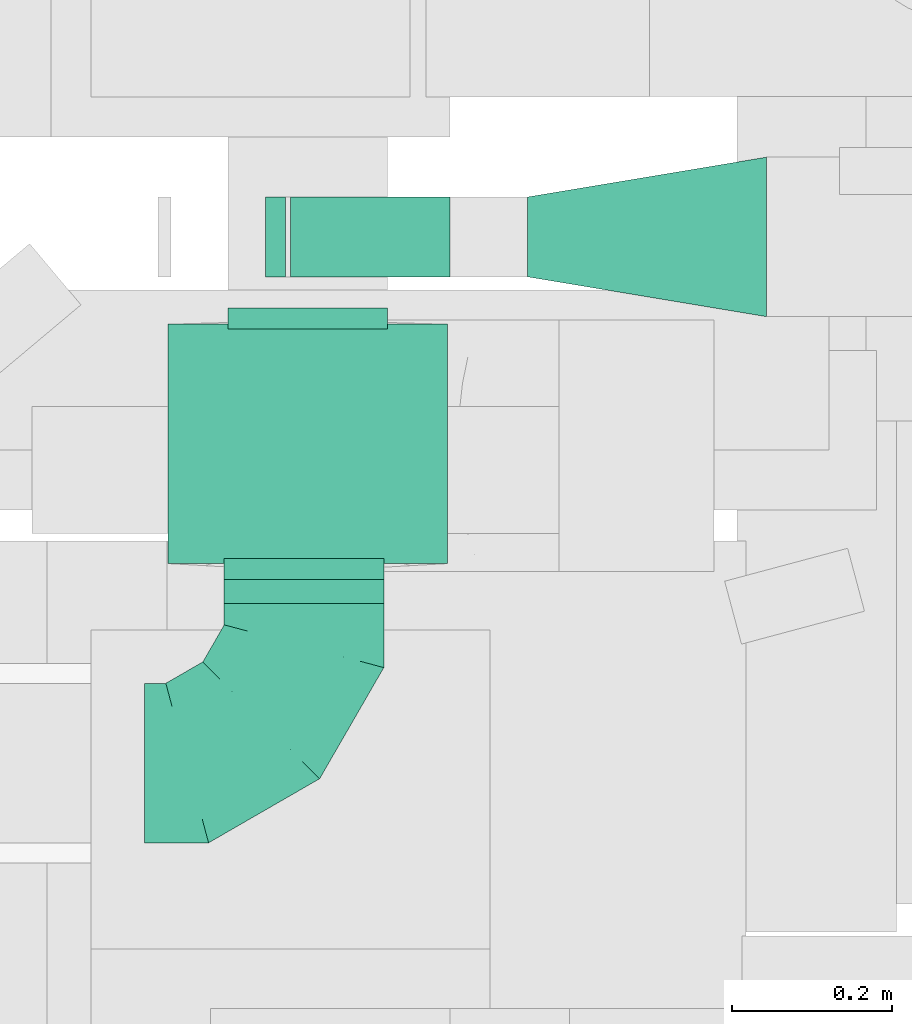
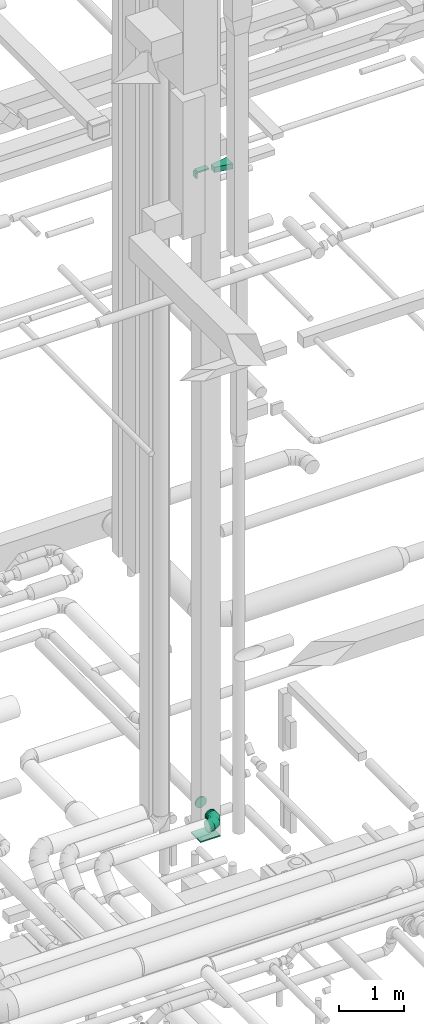
# One storey, part 197 of 337: 7 flow fittings, 1 flow segment.
"""IFC2X3 building model written with IfcOpenShell, lengths in millimetres."""

from ifc_helpers import new_model, entity, si_unit, converted_unit, derived_unit, direction, frame, origin, origin_2d_with_axis, place, context, subcontext, project, spatial, polyline, rectangle, circle, outline, extrude, faceted_brep, source, transform, mapped, material, type_object, type_shapes, element, save


model = new_model("IFC2X3")

# Units and contexts
model_context = context("Model", 3, precision=0.01, world=origin(), true_north=direction((6.12303176911189e-17, 1.0)))
body_context = subcontext(model_context, "Body", "Model", "MODEL_VIEW")
ifc_project = project(units=[si_unit("LENGTHUNIT", "METRE", prefix="MILLI"), si_unit("AREAUNIT", "SQUARE_METRE"), si_unit("VOLUMEUNIT", "CUBIC_METRE"), converted_unit("PLANEANGLEUNIT", "DEGREE", entity("IfcRatioMeasure", 0.0174532925199433), si_unit("PLANEANGLEUNIT", "RADIAN"), dimensions=[0, 0, 0, 0, 0, 0, 0]), si_unit("MASSUNIT", "GRAM", prefix="KILO"), derived_unit("MASSDENSITYUNIT", [(si_unit("MASSUNIT", "GRAM", prefix="KILO"), 1), (si_unit("LENGTHUNIT", "METRE"), -3)]), derived_unit("MOMENTOFINERTIAUNIT", [(si_unit("LENGTHUNIT", "METRE"), 4)]), si_unit("TIMEUNIT", "SECOND"), si_unit("FREQUENCYUNIT", "HERTZ"), si_unit("THERMODYNAMICTEMPERATUREUNIT", "DEGREE_CELSIUS"), derived_unit("THERMALTRANSMITTANCEUNIT", [(si_unit("MASSUNIT", "GRAM", prefix="KILO"), 1), (si_unit("THERMODYNAMICTEMPERATUREUNIT", "KELVIN"), -1), (si_unit("TIMEUNIT", "SECOND"), -3)]), derived_unit("VOLUMETRICFLOWRATEUNIT", [(si_unit("LENGTHUNIT", "METRE"), 3), (si_unit("TIMEUNIT", "SECOND"), -1)]), derived_unit("MASSFLOWRATEUNIT", [(si_unit("MASSUNIT", "GRAM", prefix="KILO"), 1), (si_unit("TIMEUNIT", "SECOND"), -1)]), derived_unit("ROTATIONALFREQUENCYUNIT", [(si_unit("TIMEUNIT", "SECOND"), -1)]), si_unit("ELECTRICCURRENTUNIT", "AMPERE"), si_unit("ELECTRICVOLTAGEUNIT", "VOLT"), si_unit("POWERUNIT", "WATT"), si_unit("FORCEUNIT", "NEWTON", prefix="KILO"), si_unit("ILLUMINANCEUNIT", "LUX"), si_unit("LUMINOUSFLUXUNIT", "LUMEN"), si_unit("LUMINOUSINTENSITYUNIT", "CANDELA"), derived_unit("USERDEFINED", [(si_unit("MASSUNIT", "GRAM", prefix="KILO"), -1), (si_unit("LENGTHUNIT", "METRE"), -2), (si_unit("TIMEUNIT", "SECOND"), 3), (si_unit("LUMINOUSFLUXUNIT", "LUMEN"), 1)]), derived_unit("LINEARVELOCITYUNIT", [(si_unit("LENGTHUNIT", "METRE"), 1), (si_unit("TIMEUNIT", "SECOND"), -1)]), si_unit("PRESSUREUNIT", "PASCAL"), derived_unit("USERDEFINED", [(si_unit("LENGTHUNIT", "METRE"), -2), (si_unit("MASSUNIT", "GRAM", prefix="KILO"), 1), (si_unit("TIMEUNIT", "SECOND"), -2)]), derived_unit("LINEARFORCEUNIT", [(si_unit("MASSUNIT", "GRAM", prefix="KILO"), 1), (si_unit("LENGTHUNIT", "METRE"), 1), (si_unit("TIMEUNIT", "SECOND"), -2), (si_unit("LENGTHUNIT", "METRE"), -1)]), derived_unit("PLANARFORCEUNIT", [(si_unit("MASSUNIT", "GRAM", prefix="KILO"), 1), (si_unit("LENGTHUNIT", "METRE"), 1), (si_unit("TIMEUNIT", "SECOND"), -2), (si_unit("LENGTHUNIT", "METRE"), -2)])], contexts=[model_context])

# Site, building, storey
site_placement = place(None, origin())
site = spatial("IfcSite", under=ifc_project, at=site_placement, CompositionType="ELEMENT")
building_placement = place(site_placement, origin())
building = spatial("IfcBuilding", under=site, at=building_placement, CompositionType="ELEMENT")
storey_placement = place(building_placement, origin())
storey = spatial("IfcBuildingStorey", under=building, at=storey_placement, CompositionType="ELEMENT", Elevation=0.0)

# Flow segment
duct_segment_type = type_object("IfcDuctSegmentType", PredefinedType="NOTDEFINED")
flow_segment_placement = place(storey_placement, frame((52465.56, 12006.96, 3348.4)))
element("IfcFlowSegment", 1, at=flow_segment_placement, inside=storey, type_object=duct_segment_type, context=body_context, shape_type="SweptSolid", body=[
    extrude(circle(Radius=100.0, at=origin_2d_with_axis()), frame((101.6, 0.0, 101.6), z_axis=(0.0, 1.0, 0.0), x_axis=(1.0, 0.0, 0.0)), (0.0, 0.0, 1.0), 29.9999999999542),
])

# Flow fittings
ifc_material = material()
duct_fitting_type_1 = type_object("IfcDuctFittingType", PredefinedType="NOTDEFINED", material=ifc_material)
shared_shape_1 = source(origin(), body_context, "Body", "SweptSolid", [
    extrude(rectangle(XDim=24.9999999999999, YDim=100.0, at=origin_2d_with_axis()), frame((12.5, 0.0, -50.0)), (0.0, 0.0, 1.0), 100.0),
])
type_shapes(duct_fitting_type_1, [shared_shape_1])
flow_fitting_1_placement = place(storey_placement, frame((52543.97, 12466.31, 15300.0), z_axis=(0.0, 0.0, 1.0), x_axis=(-1.0, 0.0, 0.0)))
element("IfcFlowFitting", 2, at=flow_fitting_1_placement, inside=storey, type_object=duct_fitting_type_1, material=ifc_material, context=body_context, shape_type="MappedRepresentation", body=[
    mapped(shared_shape_1, transform((0.0, 0.0, 0.0), scale=1.0)),
])
duct_fitting_type_2 = type_object("IfcDuctFittingType", PredefinedType="NOTDEFINED", material=ifc_material)
shared_shape_2 = source(origin(), body_context, "Body", "SweptSolid", [
    extrude(rectangle(XDim=24.9999999999999, YDim=300.0, at=origin_2d_with_axis()), frame((12.5, 0.0, -175.0)), (0.0, 0.0, 1.0), 350.0),
])
type_shapes(duct_fitting_type_2, [shared_shape_2])
flow_fitting_2_placement = place(storey_placement, frame((52571.74, 12206.96, 3000.0), z_axis=(-1.0, 0.0, 0.0), x_axis=(0.0, 0.0, -1.0)))
element("IfcFlowFitting", 3, at=flow_fitting_2_placement, inside=storey, type_object=duct_fitting_type_2, material=ifc_material, context=body_context, shape_type="MappedRepresentation", body=[
    mapped(shared_shape_2, transform((0.0, 0.0, 0.0), scale=1.0)),
])
duct_fitting_type_3 = type_object("IfcDuctFittingType", PredefinedType="NOTDEFINED", material=ifc_material)
shared_shape_3 = source(origin(), body_context, "Body", "SweptSolid", [
    extrude(outline(polyline([(-164.4, -73.98), (139.74, -73.98), (156.18, 24.66), (-131.52, 123.3), (-164.4, -73.98)])), frame((150.0, 0.0, -50.0), z_axis=(0.0, 0.0, 1.0), x_axis=(0.986393923832144, 0.164398987305356, 0.0)), (0.0, 0.0, 1.0), 100.0),
])
type_shapes(duct_fitting_type_3, [shared_shape_3])
flow_fitting_3_placement = place(storey_placement, frame((53146.97, 12466.31, 15300.0), z_axis=(0.0, 0.0, 1.0), x_axis=(-1.0, 0.0, 0.0)))
element("IfcFlowFitting", 4, at=flow_fitting_3_placement, inside=storey, type_object=duct_fitting_type_3, material=ifc_material, context=body_context, shape_type="MappedRepresentation", body=[
    mapped(shared_shape_3, transform((0.0, 0.0, 0.0), scale=1.0)),
])
duct_fitting_type_4 = type_object("IfcDuctFittingType", PredefinedType="NOTDEFINED", material=ifc_material)
shared_shape_4 = source(origin(), body_context, "Body", "SweptSolid", [
    extrude(rectangle(XDim=100.0, YDim=26.0960000000087, at=origin_2d_with_axis()), frame((6.95, 0.0, -100.0), z_axis=(0.0, 0.0, 1.0), x_axis=(0.0, -1.0, 0.0)), (0.0, 0.0, 1.0), 200.0),
])
type_shapes(duct_fitting_type_4, [shared_shape_4])
flow_fitting_4_placement = place(storey_placement, frame((52650.22, 12466.31, 15350.0), z_axis=(-1.0, 0.0, 0.0), x_axis=(0.0, 0.0, 1.0)))
element("IfcFlowFitting", 5, at=flow_fitting_4_placement, inside=storey, type_object=duct_fitting_type_4, material=ifc_material, context=body_context, shape_type="MappedRepresentation", body=[
    mapped(shared_shape_4, transform((0.0, 0.0, 0.0), scale=1.0)),
])
duct_fitting_type_5 = type_object("IfcDuctFittingType", PredefinedType="NOTDEFINED", material=ifc_material)
shared_shape_5 = source(origin(), body_context, "Body", "Brep", [
    faceted_brep([(-200.0, 0.0, -100.0), (-200.0, -25.88, -96.59), (-200.0, -50.0, -86.6), (-200.0, -70.71, -70.71), (-200.0, -86.6, -50.0), (-200.0, -96.59, -25.88), (-200.0, -100.0, 0.0), (-200.0, -96.59, 25.88), (-200.0, -86.6, 50.0), (-200.0, -70.71, 70.71), (-200.0, -50.0, 86.6), (-200.0, -25.88, 96.59), (-200.0, 0.0, 100.0), (-200.0, 25.88, 96.59), (-200.0, 50.0, 86.6), (-200.0, 70.71, 70.71), (-200.0, 86.6, 50.0), (-200.0, 96.59, 25.88), (-200.0, 100.0, 0.0), (-200.0, 96.59, -25.88), (-200.0, 86.6, -50.0), (-200.0, 70.71, -70.71), (-200.0, 50.0, -86.6), (-200.0, 25.88, -96.59), (-153.35, 25.88, 96.59), (-159.81, 50.0, 86.6), (-146.41, 0.0, 100.0), (-165.36, 70.71, 70.71), (-172.29, 96.59, 25.88), (-173.21, 100.0, 0.0), (-169.62, 86.6, 50.0), (-169.62, 86.6, -50.0), (-165.36, 70.71, -70.71), (-172.29, 96.59, -25.88), (-153.35, 25.88, -96.59), (-146.41, 0.0, -100.0), (-159.81, 50.0, -86.6), (-139.48, -25.88, -96.59), (-133.01, -50.0, -86.6), (-127.46, -70.71, -70.71), (-123.21, -86.6, -50.0), (-120.53, -96.59, -25.88), (-119.62, -100.0, 0.0), (-120.53, -96.59, 25.88), (-123.21, -86.6, 50.0), (-127.46, -70.71, 70.71), (-133.01, -50.0, 86.6), (-139.48, -25.88, 96.59), (-72.54, 72.54, 96.59), (-90.19, 90.19, 86.6), (-53.59, 53.59, 100.0), (-105.35, 105.35, 70.71), (-116.99, 116.99, 50.0), (-124.3, 124.3, 25.88), (-126.79, 126.79, 0.0), (-124.3, 124.3, -25.88), (-116.99, 116.99, -50.0), (-105.35, 105.35, -70.71), (-72.54, 72.54, -96.59), (-53.59, 53.59, -100.0), (-90.19, 90.19, -86.6), (-34.64, 34.64, -96.59), (-16.99, 16.99, -86.6), (-1.83, 1.83, -70.71), (9.81, -9.81, -50.0), (17.12, -17.12, -25.88), (19.62, -19.62, 0.0), (17.12, -17.12, 25.88), (9.81, -9.81, 50.0), (-1.83, 1.83, 70.71), (-16.99, 16.99, 86.6), (-34.64, 34.64, 96.59), (-25.88, 153.35, 96.59), (-50.0, 159.81, 86.6), (0.0, 146.41, 100.0), (-70.71, 165.36, 70.71), (-86.6, 169.62, 50.0), (-96.59, 172.29, 25.88), (-100.0, 173.21, 0.0), (-96.59, 172.29, -25.88), (-86.6, 169.62, -50.0), (-70.71, 165.36, -70.71), (-25.88, 153.35, -96.59), (0.0, 146.41, -100.0), (-50.0, 159.81, -86.6), (25.88, 139.48, -96.59), (50.0, 133.01, -86.6), (70.71, 127.46, -70.71), (86.6, 123.21, -50.0), (96.59, 120.53, -25.88), (100.0, 119.62, 0.0), (96.59, 120.53, 25.88), (86.6, 123.21, 50.0), (70.71, 127.46, 70.71), (50.0, 133.01, 86.6), (25.88, 139.48, 96.59), (-25.88, 200.0, -96.59), (-50.0, 200.0, -86.6), (-70.71, 200.0, -70.71), (-86.6, 200.0, -50.0), (-96.59, 200.0, -25.88), (-100.0, 200.0, 0.0), (-96.59, 200.0, 25.88), (-86.6, 200.0, 50.0), (-70.71, 200.0, 70.71), (-50.0, 200.0, 86.6), (-25.88, 200.0, 96.59), (0.0, 200.0, 100.0), (25.88, 200.0, 96.59), (50.0, 200.0, 86.6), (70.71, 200.0, 70.71), (86.6, 200.0, 50.0), (96.59, 200.0, 25.88), (100.0, 200.0, 0.0), (96.59, 200.0, -25.88), (86.6, 200.0, -50.0), (70.71, 200.0, -70.71), (50.0, 200.0, -86.6), (25.88, 200.0, -96.59), (0.0, 200.0, -100.0)], [[[0, 1, 2, 3, 4, 5, 6, 7, 8, 9, 10, 11, 12, 13, 14, 15, 16, 17, 18, 19, 20, 21, 22, 23]], [[24, 25, 14, 13]], [[26, 24, 13, 12]], [[14, 25, 27, 15]], [[28, 29, 18, 17]], [[30, 28, 17, 16]], [[15, 27, 30, 16]], [[20, 31, 32, 21]], [[33, 31, 20, 19]], [[18, 29, 33, 19]], [[34, 35, 0, 23]], [[36, 34, 23, 22]], [[32, 36, 22, 21]], [[1, 0, 35, 37]], [[2, 1, 37, 38]], [[38, 39, 3, 2]], [[5, 4, 40, 41]], [[6, 5, 41, 42]], [[39, 40, 4, 3]], [[6, 42, 43, 7]], [[7, 43, 44, 8]], [[8, 44, 45, 9]], [[9, 45, 46, 10]], [[10, 46, 47, 11]], [[26, 12, 11, 47]], [[48, 49, 25, 24]], [[50, 48, 24, 26]], [[27, 25, 49, 51]], [[52, 53, 28, 30]], [[51, 52, 30, 27]], [[29, 28, 53, 54]], [[55, 56, 31, 33]], [[54, 55, 33, 29]], [[32, 31, 56, 57]], [[58, 59, 35, 34]], [[60, 58, 34, 36]], [[57, 60, 36, 32]], [[37, 35, 59, 61]], [[38, 37, 61, 62]], [[39, 38, 62, 63]], [[41, 40, 64, 65]], [[42, 41, 65, 66]], [[63, 64, 40, 39]], [[43, 42, 66, 67]], [[44, 43, 67, 68]], [[68, 69, 45, 44]], [[46, 45, 69, 70]], [[47, 46, 70, 71]], [[26, 47, 71, 50]], [[72, 73, 49, 48]], [[74, 72, 48, 50]], [[51, 49, 73, 75]], [[76, 77, 53, 52]], [[75, 76, 52, 51]], [[54, 53, 77, 78]], [[79, 80, 56, 55]], [[78, 79, 55, 54]], [[57, 56, 80, 81]], [[82, 83, 59, 58]], [[84, 82, 58, 60]], [[81, 84, 60, 57]], [[61, 59, 83, 85]], [[62, 61, 85, 86]], [[63, 62, 86, 87]], [[65, 64, 88, 89]], [[66, 65, 89, 90]], [[87, 88, 64, 63]], [[67, 66, 90, 91]], [[68, 67, 91, 92]], [[92, 93, 69, 68]], [[70, 69, 93, 94]], [[71, 70, 94, 95]], [[50, 71, 95, 74]], [[96, 97, 98, 99, 100, 101, 102, 103, 104, 105, 106, 107, 108, 109, 110, 111, 112, 113, 114, 115, 116, 117, 118, 119]], [[72, 74, 107, 106]], [[73, 72, 106, 105]], [[75, 73, 105, 104]], [[102, 101, 78, 77]], [[103, 102, 77, 76]], [[75, 104, 103, 76]], [[78, 101, 100, 79]], [[79, 100, 99, 80]], [[80, 99, 98, 81]], [[84, 97, 96, 82]], [[82, 96, 119, 83]], [[84, 81, 98, 97]], [[118, 117, 86, 85]], [[119, 118, 85, 83]], [[116, 87, 86, 117]], [[88, 115, 114, 89]], [[89, 114, 113, 90]], [[115, 88, 87, 116]], [[91, 90, 113, 112]], [[92, 91, 112, 111]], [[111, 110, 93, 92]], [[95, 94, 109, 108]], [[74, 95, 108, 107]], [[110, 109, 94, 93]]]),
])
type_shapes(duct_fitting_type_5, [shared_shape_5])
flow_fitting_5_placement = place(storey_placement, frame((52567.16, 11806.96, 3450.0)))
element("IfcFlowFitting", 6, at=flow_fitting_5_placement, inside=storey, type_object=duct_fitting_type_5, material=ifc_material, context=body_context, shape_type="MappedRepresentation", body=[
    mapped(shared_shape_5, transform((0.0, 0.0, 0.0), scale=1.0)),
])
duct_fitting_type_6 = type_object("IfcDuctFittingType", PredefinedType="NOTDEFINED", material=ifc_material)
shared_shape_6 = source(origin(), body_context, "Body", "Brep", [
    faceted_brep([(20.0, 25.88, -96.59), (20.0, 50.0, -86.6), (20.0, 70.71, -70.71), (20.0, 86.6, -50.0), (20.0, 96.59, -25.88), (20.0, 100.0, 0.0), (20.0, 96.59, 25.88), (20.0, 86.6, 50.0), (20.0, 70.71, 70.71), (20.0, 50.0, 86.6), (20.0, 25.88, 96.59), (20.0, 0.0, 100.0), (20.0, -25.88, 96.59), (20.0, -50.0, 86.6), (20.0, -70.71, 70.71), (20.0, -86.6, 50.0), (20.0, -96.59, 25.88), (20.0, -100.0, 0.0), (20.0, -96.59, -25.88), (20.0, -86.6, -50.0), (20.0, -70.71, -70.71), (20.0, -50.0, -86.6), (20.0, -25.88, -96.59), (20.0, 0.0, -100.0), (0.0, 0.0, 100.0), (0.0, 25.88, 96.59), (-6.1, 25.88, 96.59), (-6.1, 0.0, 100.0), (0.0, 50.0, 86.6), (-6.1, 50.0, 86.6), (0.0, 70.71, 70.71), (-6.1, 70.71, 70.71), (0.0, 86.6, 50.0), (0.0, 96.59, 25.88), (-6.1, 96.59, 25.88), (-6.1, 86.6, 50.0), (0.0, 100.0, 0.0), (-6.1, 100.0, 0.0), (0.0, 96.59, -25.88), (-6.1, 96.59, -25.88), (0.0, 86.6, -50.0), (-6.1, 86.6, -50.0), (0.0, 70.71, -70.71), (-6.1, 70.71, -70.71), (0.0, 50.0, -86.6), (0.0, 25.88, -96.59), (-6.1, 25.88, -96.59), (-6.1, 50.0, -86.6), (0.0, 0.0, -100.0), (-6.1, 0.0, -100.0), (0.0, -25.88, -96.59), (-6.1, -25.88, -96.59), (0.0, -50.0, -86.6), (-6.1, -50.0, -86.6), (0.0, -70.71, -70.71), (-6.1, -70.71, -70.71), (0.0, -86.6, -50.0), (0.0, -96.59, -25.88), (-6.1, -96.59, -25.88), (-6.1, -86.6, -50.0), (0.0, -100.0, 0.0), (-6.1, -100.0, 0.0), (0.0, -96.59, 25.88), (-6.1, -96.59, 25.88), (0.0, -86.6, 50.0), (-6.1, -86.6, 50.0), (0.0, -70.71, 70.71), (-6.1, -70.71, 70.71), (0.0, -50.0, 86.6), (0.0, -25.88, 96.59), (-6.1, -25.88, 96.59), (-6.1, -50.0, 86.6)], [[[0, 1, 2, 3, 4, 5, 6, 7, 8, 9, 10, 11, 12, 13, 14, 15, 16, 17, 18, 19, 20, 21, 22, 23]], [[24, 11, 10, 25, 26, 27]], [[25, 10, 9, 28, 29, 26]], [[28, 9, 8, 30, 31, 29]], [[32, 7, 6, 33, 34, 35]], [[33, 6, 5, 36, 37, 34]], [[30, 8, 7, 32, 35, 31]], [[36, 5, 4, 38, 39, 37]], [[38, 4, 3, 40, 41, 39]], [[40, 3, 2, 42, 43, 41]], [[44, 1, 0, 45, 46, 47]], [[45, 0, 23, 48, 49, 46]], [[42, 2, 1, 44, 47, 43]], [[48, 23, 22, 50, 51, 49]], [[50, 22, 21, 52, 53, 51]], [[52, 21, 20, 54, 55, 53]], [[56, 19, 18, 57, 58, 59]], [[57, 18, 17, 60, 61, 58]], [[54, 20, 19, 56, 59, 55]], [[60, 17, 16, 62, 63, 61]], [[62, 16, 15, 64, 65, 63]], [[64, 15, 14, 66, 67, 65]], [[68, 13, 12, 69, 70, 71]], [[69, 12, 11, 24, 27, 70]], [[66, 14, 13, 68, 71, 67]], [[49, 51, 53, 55, 59, 58, 61, 63, 65, 67, 71, 70, 27, 26, 29, 31, 35, 34, 37, 39, 41, 43, 47, 46]]]),
])
type_shapes(duct_fitting_type_6, [shared_shape_6])
for number, where, z_axis, x_axis in (
    (7, (52571.74, 12356.96, 3500.0), (1.0, 0.0, 0.0), (0.0, 1.0, 0.0)),
    (8, (52567.16, 12056.96, 3450.0), (-1.0, 0.0, 0.0), (0.0, -1.0, 0.0)),
):
    element("IfcFlowFitting", number, at=place(storey_placement, frame(where, z_axis=z_axis, x_axis=x_axis)), inside=storey, type_object=duct_fitting_type_6, material=ifc_material, context=body_context, shape_type="MappedRepresentation", body=[
        mapped(shared_shape_6, transform((0.0, 0.0, 0.0), scale=1.0)),
    ])

save(model, "model.ifc")
